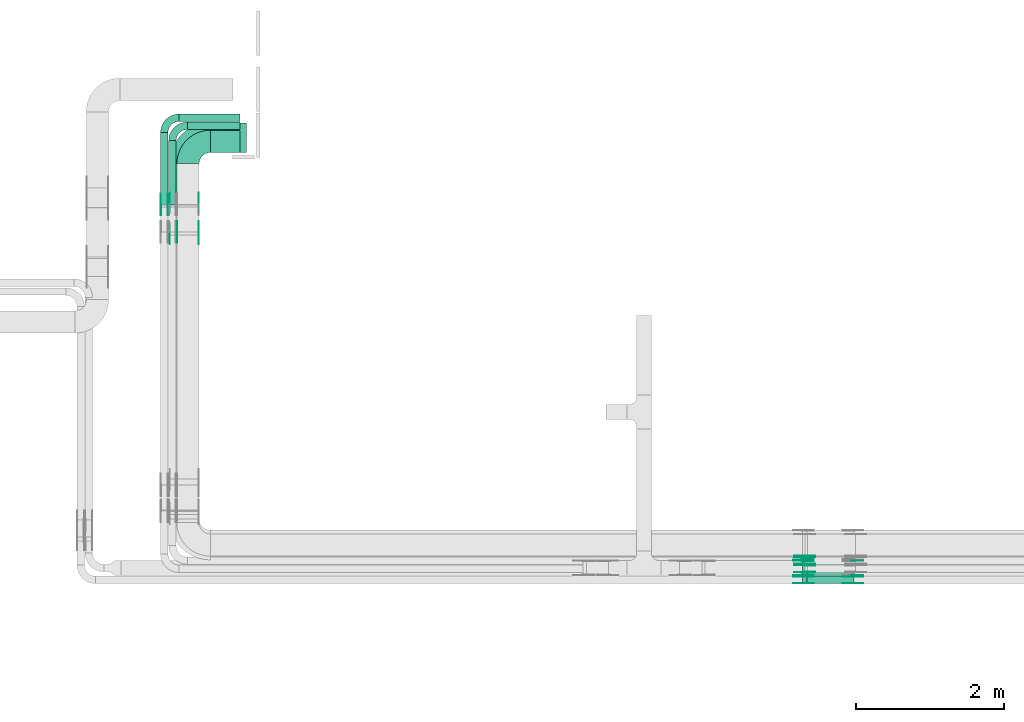
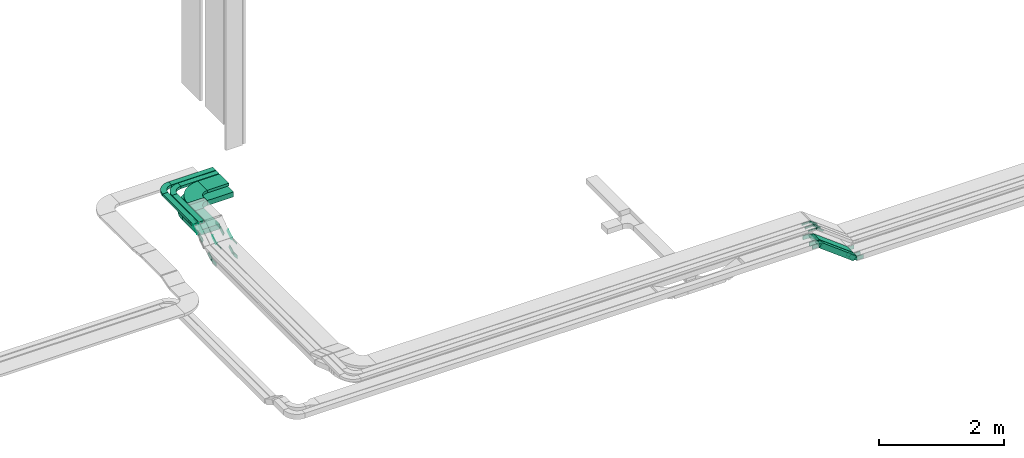
# One storey, part 9 of 28: 46 flow fittings, 9 flow segments.
"""IFC2X3 building model written with IfcOpenShell, lengths in millimetres."""

import ifcopenshell
import ifcopenshell.guid

model = None  # the IFC model being written
_history = None  # IfcOwnerHistory: only IFC2X3 demands one
_inside = {}  # id of a spatial element -> (the spatial element, [elements in it])
_under = {}  # id of a project, library or spatial element -> (it, [spatial elements below it])
_declared = {}  # id of a project -> (the project, [libraries it declares])
_typed = {}  # id of a type object -> (the type object, [elements of that type])
_made_of = {}  # id of a material, layer set ... -> (it, [elements and type objects made of it])


def new_model(schema):
    """Start an empty IFC model of exactly this schema.

    Asked for "IFC4X3", IfcOpenShell would pick the latest addendum, in which some entities
    have other attributes; the version numbers below select the first issue.
    IFC2X3 requires an IfcOwnerHistory on every rooted entity: one is made here for all.
    """
    global model, _history
    if schema == "IFC4X3":
        model = ifcopenshell.file(schema_version=(4, 3, 0, 0))
    else:
        model = ifcopenshell.file(schema=schema)
    _inside.clear()
    _under.clear()
    _declared.clear()
    _typed.clear()
    _made_of.clear()
    _history = None
    if model.schema == "IFC2X3":
        org = make("IfcOrganization", Name="unknown")
        user = make(
            "IfcPersonAndOrganization",
            ThePerson=make("IfcPerson", FamilyName="unknown"),
            TheOrganization=org,
        )
        app = make(
            "IfcApplication",
            ApplicationDeveloper=org,
            Version="unknown",
            ApplicationFullName="unknown",
            ApplicationIdentifier="unknown",
        )
        _history = make(
            "IfcOwnerHistory",
            OwningUser=user,
            OwningApplication=app,
            ChangeAction="ADDED",
            CreationDate=0,
        )
    return model


def make(cls, **values):
    """One entity of the class cls with the attributes given. An attribute that is None is left unset."""
    return model.create_entity(
        cls, **{name: value for name, value in values.items() if value is not None}
    )


def entity(cls, *values):
    """Any entity or typed value of the class cls, its attributes in the order of the schema. None: left unset."""
    e = model.create_entity(cls)
    for i, value in enumerate(values):
        if value is not None:
            e[i] = value
    return e


def rooted(cls, **values):
    """An entity with a GlobalId (a new one), such as an element, a storey or a relation."""
    return make(cls, GlobalId=ifcopenshell.guid.new(), OwnerHistory=_history, **values)


def si_unit(unit_type, name, prefix=None):
    """IfcSIUnit, for example si_unit("LENGTHUNIT", "METRE", prefix="MILLI")."""
    return make("IfcSIUnit", UnitType=unit_type, Prefix=prefix, Name=name)


def converted_unit(unit_type, name, factor, base, dimensions=None, offset=None):
    """IfcConversionBasedUnit, such as the inch: factor (a typed value) times the base unit."""
    return make(
        "IfcConversionBasedUnit"
        if offset is None
        else "IfcConversionBasedUnitWithOffset",
        ConversionOffset=offset,
        Dimensions=None
        if dimensions is None
        else entity("IfcDimensionalExponents", *dimensions),
        UnitType=unit_type,
        Name=name,
        ConversionFactor=make(
            "IfcMeasureWithUnit", ValueComponent=factor, UnitComponent=base
        ),
    )


def derived_unit(unit_type, elements):
    """IfcDerivedUnit: a product of units, each with its exponent."""
    return make(
        "IfcDerivedUnit",
        Elements=[
            make("IfcDerivedUnitElement", Unit=unit, Exponent=power)
            for unit, power in elements
        ],
        UnitType=unit_type,
    )


def assignment(units):
    """IfcUnitAssignment: the units of a project."""
    return None if units is None else make("IfcUnitAssignment", Units=units)


def point(xyz):
    """IfcCartesianPoint."""
    return None if xyz is None else make("IfcCartesianPoint", Coordinates=xyz)


def direction(xyz):
    """IfcDirection."""
    return None if xyz is None else make("IfcDirection", DirectionRatios=xyz)


def frame(location, z_axis=None, x_axis=None):
    """IfcAxis2Placement3D, a coordinate frame: its origin and axes. An axis left out is left unset."""
    return make(
        "IfcAxis2Placement3D",
        Location=point(location),
        Axis=direction(z_axis),
        RefDirection=direction(x_axis),
    )


def frame_2d(location, x_axis=None):
    """IfcAxis2Placement2D, a coordinate frame in the plane: its origin and x axis."""
    return make(
        "IfcAxis2Placement2D", Location=point(location), RefDirection=direction(x_axis)
    )


def origin():
    """The frame at (0, 0, 0) with its axes left unset."""
    return frame((0.0, 0.0, 0.0))


def place(relative_to, where):
    """IfcLocalPlacement: puts the frame where relative to a parent placement (None: the world)."""
    return make(
        "IfcLocalPlacement", PlacementRelTo=relative_to, RelativePlacement=where
    )


def context(
    kind, dimensions, precision=None, world=None, true_north=None, identifier=None
):
    """IfcGeometricRepresentationContext, for example the 3D "Model" context."""
    return make(
        "IfcGeometricRepresentationContext",
        ContextIdentifier=identifier,
        ContextType=kind,
        CoordinateSpaceDimension=dimensions,
        Precision=precision,
        WorldCoordinateSystem=world,
        TrueNorth=true_north,
    )


def subcontext(parent, identifier, kind, view, scale=None):
    """IfcGeometricRepresentationSubContext, for example "Body" below "Model"."""
    return make(
        "IfcGeometricRepresentationSubContext",
        ContextIdentifier=identifier,
        ContextType=kind,
        ParentContext=parent,
        TargetScale=scale,
        TargetView=view,
    )


def project(units=None, contexts=None):
    """IfcProject with its units and contexts."""
    return rooted(
        "IfcProject",
        Name="project",
        RepresentationContexts=contexts,
        UnitsInContext=assignment(units),
    )


def spatial(cls, under=None, at=None, **own):
    """A site, building, storey or space (cls), placed at a placement, below another one or the project."""
    s = rooted(cls, ObjectPlacement=at, **own)
    if under is not None:
        _under.setdefault(under.id(), (under, []))[1].append(s)
    return s


def polyline(points):
    """IfcPolyline through the points."""
    return make("IfcPolyline", Points=[point(p) for p in points])


def circle_curve(where, radius):
    """IfcCircle in the frame where."""
    return make("IfcCircle", Position=where, Radius=radius)


def parameter(value):
    """IfcParameterValue: where a trimmed curve begins or ends, as a parameter of its basis curve."""
    return model.create_entity("IfcParameterValue", value)


def trimmed(basis, trim1, trim2, sense, master):
    """IfcTrimmedCurve: the piece of a basis curve between two trims."""
    return make(
        "IfcTrimmedCurve",
        BasisCurve=basis,
        Trim1=trim1,
        Trim2=trim2,
        SenseAgreement=sense,
        MasterRepresentation=master,
    )


def segment(curve, same_sense, transition):
    """IfcCompositeCurveSegment."""
    return make(
        "IfcCompositeCurveSegment",
        Transition=transition,
        SameSense=same_sense,
        ParentCurve=curve,
    )


def composite_curve(segments, self_intersect=None):
    """IfcCompositeCurve: segments joined end to end."""
    return make("IfcCompositeCurve", Segments=segments, SelfIntersect=self_intersect)


def profile(cls, at=None, kind="AREA", **sizes):
    """A parametric profile (cls). Its sizes go by their IFC names, for example OverallWidth=200.0."""
    return make(cls, ProfileType=kind, Position=at, **sizes)


def rectangle(**sizes):
    """IfcRectangleProfileDef."""
    return profile("IfcRectangleProfileDef", **sizes)


def outline(outer, holes=None, kind="AREA"):
    """IfcArbitraryClosedProfileDef: a profile drawn as a closed curve; with holes, ...WithVoids."""
    if holes is None:
        return make("IfcArbitraryClosedProfileDef", ProfileType=kind, OuterCurve=outer)
    return make(
        "IfcArbitraryProfileDefWithVoids",
        ProfileType=kind,
        OuterCurve=outer,
        InnerCurves=holes,
    )


def extrude(swept, where, along, depth):
    """IfcExtrudedAreaSolid: the profile swept, set in the frame where, extruded along a direction by depth."""
    return make(
        "IfcExtrudedAreaSolid",
        SweptArea=swept,
        Position=where,
        ExtrudedDirection=direction(along),
        Depth=depth,
    )


def shape(context_of_items, identifier, shape_type, items):
    """IfcShapeRepresentation: the items that make up one representation, for example the "Body"."""
    return make(
        "IfcShapeRepresentation",
        ContextOfItems=context_of_items,
        RepresentationIdentifier=identifier,
        RepresentationType=shape_type,
        Items=items,
    )


def source(mapping_origin, context_of_items, identifier, shape_type, items):
    """IfcRepresentationMap: a shape defined once, which mapped items show again and again."""
    return make(
        "IfcRepresentationMap",
        MappingOrigin=mapping_origin,
        MappedRepresentation=shape(context_of_items, identifier, shape_type, items),
    )


def transform(
    local_origin,
    x_axis=None,
    y_axis=None,
    z_axis=None,
    scale=None,
    scale2=None,
    scale3=None,
    uniform=True,
):
    """IfcCartesianTransformationOperator3D, or its non-uniform kind. x_axis, y_axis, z_axis: its Axis1, 2, 3."""
    if uniform:
        return make(
            "IfcCartesianTransformationOperator3D",
            Axis1=direction(x_axis),
            Axis2=direction(y_axis),
            LocalOrigin=point(local_origin),
            Scale=scale,
            Axis3=direction(z_axis),
        )
    return make(
        "IfcCartesianTransformationOperator3DnonUniform",
        Axis1=direction(x_axis),
        Axis2=direction(y_axis),
        LocalOrigin=point(local_origin),
        Scale=scale,
        Axis3=direction(z_axis),
        Scale2=scale2,
        Scale3=scale3,
    )


def mapped(mapping_source, mapping_target):
    """IfcMappedItem: shows the shape of a source again, moved by a transform."""
    return make(
        "IfcMappedItem", MappingSource=mapping_source, MappingTarget=mapping_target
    )


def material(Name=None, Category=None):
    """IfcMaterial."""
    return make("IfcMaterial", Name=Name, Category=Category)


def made_of(thing, what):
    """Note that an element or type object is made of a material, layer set ...; save() writes the relation."""
    if what is not None:
        _made_of.setdefault(what.id(), (what, []))[1].append(thing)
    return thing


def type_object(cls, material=None, **own):
    """A type object (cls), such as IfcWallType, which elements share."""
    return made_of(rooted(cls, **own), material)


def type_shapes(of_type, sources):
    """Give a type object the sources (RepresentationMaps) that its elements show as mapped items."""
    of_type.RepresentationMaps = sources


def element(
    cls,
    number,
    at=None,
    inside=None,
    cuts=None,
    type_object=None,
    material=None,
    context=None,
    identifier="Body",
    shape_type=None,
    held_by="IfcProductDefinitionShape",
    body=None,
    shapes=None,
    **own,
):
    """One element of the class cls, such as IfcWall. Its Tag is "e" and its number.

    at: its placement. inside: the storey or other place that contains it. cuts: it is an
    opening in that element (IfcRelVoidsElement). A single representation is given by context,
    identifier, shape_type and body (its items); several are given by shapes. held_by: the class
    of the entity that holds the representations. save() writes the other relations.
    """
    e = rooted(cls, Tag="e%d" % number, ObjectPlacement=at, **own)
    if body is not None:
        shapes = [shape(context, identifier, shape_type, body)]
    if shapes is not None:
        e.Representation = make(held_by, Representations=shapes)
    if inside is not None:
        _inside.setdefault(inside.id(), (inside, []))[1].append(e)
    if cuts is not None:
        rooted(
            "IfcRelVoidsElement", RelatingBuildingElement=cuts, RelatedOpeningElement=e
        )
    if type_object is not None:
        _typed.setdefault(type_object.id(), (type_object, []))[1].append(e)
    return made_of(e, material)


def aggregate(whole, parts):
    """IfcRelAggregates: a whole, such as a stair, and the parts it consists of."""
    return rooted("IfcRelAggregates", RelatingObject=whole, RelatedObjects=parts)


def save(model, path):
    """Write the relations noted so far, then the file.

    IfcRelAggregates (storeys below a building ...), IfcRelContainedInSpatialStructure (elements
    in a storey), IfcRelDefinesByType, IfcRelAssociatesMaterial and IfcRelDeclares: one each for
    every whole, place, type object, material and project.
    """
    for whole, parts in _under.values():
        aggregate(whole, parts)
    for where, things in _inside.values():
        rooted(
            "IfcRelContainedInSpatialStructure",
            RelatedElements=things,
            RelatingStructure=where,
        )
    for kind, things in _typed.values():
        rooted("IfcRelDefinesByType", RelatedObjects=things, RelatingType=kind)
    for what, things in _made_of.values():
        rooted("IfcRelAssociatesMaterial", RelatedObjects=things, RelatingMaterial=what)
    for by, libraries in _declared.values():
        rooted("IfcRelDeclares", RelatingContext=by, RelatedDefinitions=libraries)
    model.write(path)


model = new_model("IFC2X3")

# Units and contexts
model_context = context("Model", 3, precision=0.01, world=origin(), true_north=direction((6.12303176911189e-17, 1.0)))
body_context = subcontext(model_context, "Body", "Model", "MODEL_VIEW")
ifc_project = project(units=[si_unit("LENGTHUNIT", "METRE", prefix="MILLI"), si_unit("AREAUNIT", "SQUARE_METRE"), si_unit("VOLUMEUNIT", "CUBIC_METRE"), converted_unit("PLANEANGLEUNIT", "DEGREE", entity("IfcRatioMeasure", 0.0174532925199433), si_unit("PLANEANGLEUNIT", "RADIAN"), dimensions=[0, 0, 0, 0, 0, 0, 0]), si_unit("MASSUNIT", "GRAM", prefix="KILO"), derived_unit("MASSDENSITYUNIT", [(si_unit("MASSUNIT", "GRAM", prefix="KILO"), 1), (si_unit("LENGTHUNIT", "METRE"), -3)]), derived_unit("MOMENTOFINERTIAUNIT", [(si_unit("LENGTHUNIT", "METRE"), 4)]), si_unit("TIMEUNIT", "SECOND"), si_unit("FREQUENCYUNIT", "HERTZ"), si_unit("THERMODYNAMICTEMPERATUREUNIT", "DEGREE_CELSIUS"), derived_unit("THERMALTRANSMITTANCEUNIT", [(si_unit("MASSUNIT", "GRAM", prefix="KILO"), 1), (si_unit("THERMODYNAMICTEMPERATUREUNIT", "KELVIN"), -1), (si_unit("TIMEUNIT", "SECOND"), -3)]), derived_unit("VOLUMETRICFLOWRATEUNIT", [(si_unit("LENGTHUNIT", "METRE"), 3), (si_unit("TIMEUNIT", "SECOND"), -1)]), derived_unit("MASSFLOWRATEUNIT", [(si_unit("MASSUNIT", "GRAM", prefix="KILO"), 1), (si_unit("TIMEUNIT", "SECOND"), -1)]), derived_unit("ROTATIONALFREQUENCYUNIT", [(si_unit("TIMEUNIT", "SECOND"), -1)]), si_unit("ELECTRICCURRENTUNIT", "AMPERE"), si_unit("ELECTRICVOLTAGEUNIT", "VOLT"), si_unit("POWERUNIT", "WATT"), si_unit("FORCEUNIT", "NEWTON", prefix="KILO"), si_unit("ILLUMINANCEUNIT", "LUX"), si_unit("LUMINOUSFLUXUNIT", "LUMEN"), si_unit("LUMINOUSINTENSITYUNIT", "CANDELA"), derived_unit("USERDEFINED", [(si_unit("MASSUNIT", "GRAM", prefix="KILO"), -1), (si_unit("LENGTHUNIT", "METRE"), -2), (si_unit("TIMEUNIT", "SECOND"), 3), (si_unit("LUMINOUSFLUXUNIT", "LUMEN"), 1)]), derived_unit("LINEARVELOCITYUNIT", [(si_unit("LENGTHUNIT", "METRE"), 1), (si_unit("TIMEUNIT", "SECOND"), -1)]), si_unit("PRESSUREUNIT", "PASCAL"), derived_unit("USERDEFINED", [(si_unit("LENGTHUNIT", "METRE"), -2), (si_unit("MASSUNIT", "GRAM", prefix="KILO"), 1), (si_unit("TIMEUNIT", "SECOND"), -2)]), derived_unit("LINEARFORCEUNIT", [(si_unit("MASSUNIT", "GRAM", prefix="KILO"), 1), (si_unit("LENGTHUNIT", "METRE"), 1), (si_unit("TIMEUNIT", "SECOND"), -2), (si_unit("LENGTHUNIT", "METRE"), -1)]), derived_unit("PLANARFORCEUNIT", [(si_unit("MASSUNIT", "GRAM", prefix="KILO"), 1), (si_unit("LENGTHUNIT", "METRE"), 1), (si_unit("TIMEUNIT", "SECOND"), -2), (si_unit("LENGTHUNIT", "METRE"), -2)])], contexts=[model_context])

# Site, building, storey
site_placement = place(None, frame((0.0, -0.00077364408347762, 0.0)))
site = spatial("IfcSite", under=ifc_project, at=site_placement, CompositionType="ELEMENT")
building_placement = place(site_placement, origin())
building = spatial("IfcBuilding", under=site, at=building_placement, CompositionType="ELEMENT")
storey_placement = place(building_placement, origin())
storey = spatial("IfcBuildingStorey", under=building, at=storey_placement, CompositionType="ELEMENT", Elevation=0.0)

# Flow segments
cable_carrier_segment_type = type_object("IfcCableCarrierSegmentType", PredefinedType="CABLETRAYSEGMENT")
flow_segment_1_placement = place(storey_placement, frame((23829.8620384306, 8250.00006103528, 2621.54372197819)))
element("IfcFlowSegment", 1, at=flow_segment_1_placement, inside=storey, type_object=cable_carrier_segment_type, context=body_context, shape_type="SweptSolid", body=[
    extrude(rectangle(XDim=100.000000000001, YDim=100.000000000001, at=frame_2d((0.0, -2.1316282072803e-13), x_axis=(0.0, 1.0))), frame((30.0907511576048, 50.0, 516.980780541228), z_axis=(0.79863551004726, 0.0, -0.601815023152092), x_axis=(0.0, 1.0, 0.0)), (0.0, 0.0, 1.0), 792.683776055081),
])
flow_segment_2_placement = place(storey_placement, frame((23829.8620384306, 8360.00006103512, 2621.54372197827)))
element("IfcFlowSegment", 2, at=flow_segment_2_placement, inside=storey, type_object=cable_carrier_segment_type, context=body_context, shape_type="SweptSolid", body=[
    extrude(rectangle(XDim=99.9999999999992, YDim=200.0, at=frame_2d((0.0, 0.0), x_axis=(0.0, 1.0))), frame((30.0907511575918, 100.0, 516.980780541007), z_axis=(0.798635510047449, 0.0, -0.601815023151841), x_axis=(0.0, 1.0, 0.0)), (0.0, 0.0, 1.0), 792.683776055017),
])
flow_segment_3_placement = place(storey_placement, frame((15850.9969238281, 14057.5618465678, 3450.0)))
element("IfcFlowSegment", 3, at=flow_segment_3_placement, inside=storey, type_object=cable_carrier_segment_type, context=body_context, shape_type="SweptSolid", body=[
    extrude(rectangle(XDim=399.000000000009, YDim=300.000000000001, at=frame_2d((0.0, -2.17426077142591e-12), x_axis=(1.0, 0.0))), frame((199.500000000004, 150.0, 0.0)), (0.0, 0.0, 1.0), 49.9999999999989),
])
flow_segment_4_placement = place(storey_placement, frame((15289.9969238281, 13356.5685293336, 3450.0)))
element("IfcFlowSegment", 4, at=flow_segment_4_placement, inside=storey, type_object=cable_carrier_segment_type, context=body_context, shape_type="SweptSolid", body=[
    extrude(rectangle(XDim=859.993317234152, YDim=99.9999999999989, at=frame_2d((1.08002495835535e-12, 1.08357767203415e-12), x_axis=(1.0, 0.0))), frame((50.0, 429.996658617077, 0.0), z_axis=(0.0, 0.0, 1.0), x_axis=(0.0, 1.0, 0.0)), (0.0, 0.0, 1.0), 49.9999999999995),
])
flow_segment_5_placement = place(storey_placement, frame((15540.9969238281, 14367.5618465678, 3450.0)))
element("IfcFlowSegment", 5, at=flow_segment_5_placement, inside=storey, type_object=cable_carrier_segment_type, context=body_context, shape_type="SweptSolid", body=[
    extrude(rectangle(XDim=709.000000000006, YDim=99.9999999999989, at=frame_2d((-1.08002495835535e-12, 0.0), x_axis=(1.0, 0.0))), frame((354.500000000002, 50.0, 0.0)), (0.0, 0.0, 1.0), 49.9999999999995),
])
flow_segment_6_placement = place(storey_placement, frame((15179.9969238281, 13356.5685293336, 3450.0)))
element("IfcFlowSegment", 6, at=flow_segment_6_placement, inside=storey, type_object=cable_carrier_segment_type, context=body_context, shape_type="SweptSolid", body=[
    extrude(rectangle(XDim=969.993317234148, YDim=99.9999999999989, at=frame_2d((1.08002495835535e-12, 1.08357767203415e-12), x_axis=(1.0, 0.0))), frame((50.0, 484.996658617073, 0.0), z_axis=(0.0, 0.0, 1.0), x_axis=(0.0, 1.0, 0.0)), (0.0, 0.0, 1.0), 50.0),
])
flow_segment_7_placement = place(storey_placement, frame((15430.9969238281, 14477.5618465678, 3450.0)))
element("IfcFlowSegment", 7, at=flow_segment_7_placement, inside=storey, type_object=cable_carrier_segment_type, context=body_context, shape_type="SweptSolid", body=[
    extrude(rectangle(XDim=819.000000000007, YDim=99.9999999999989, at=frame_2d((1.08002495835535e-12, 0.0), x_axis=(1.0, 0.0))), frame((409.5, 50.0, 0.0)), (0.0, 0.0, 1.0), 49.9999999999995),
])
flow_segment_8_placement = place(storey_placement, frame((15299.9969238281, 13393.6373317523, 3200.0)))
element("IfcFlowSegment", 8, at=flow_segment_8_placement, inside=storey, type_object=cable_carrier_segment_type, context=body_context, shape_type="SweptSolid", body=[
    extrude(rectangle(XDim=512.924514815445, YDim=400.0, at=frame_2d((-2.1600499167107e-12, 0.0), x_axis=(1.0, 0.0))), frame((200.0, 256.462257407734, 0.0), z_axis=(0.0, 0.0, 1.0), x_axis=(0.0, -1.0, 0.0)), (0.0, 0.0, 1.0), 99.9999999999995),
])
flow_segment_9_placement = place(storey_placement, frame((15850.9969238281, 14057.5618465678, 3200.0)))
element("IfcFlowSegment", 9, at=flow_segment_9_placement, inside=storey, type_object=cable_carrier_segment_type, context=body_context, shape_type="SweptSolid", body=[
    extrude(rectangle(XDim=489.000000000008, YDim=400.0, at=frame_2d((-1.08002495835535e-12, -1.09423581307055e-12), x_axis=(1.0, 0.0))), frame((244.500000000005, 200.0, 0.0)), (0.0, 0.0, 1.0), 100.0),
])

# Flow fittings
ifc_material_1 = material(Name="G")
cable_carrier_fitting_type_1 = type_object("IfcCableCarrierFittingType", PredefinedType="NOTDEFINED", material=ifc_material_1)
shared_shape_1 = source(origin(), body_context, "Body", "SweptSolid", [
    extrude(outline(composite_curve([segment(trimmed(circle_curve(frame_2d((-44.5901162790698, 0.0), x_axis=(1.0, 0.0)), 12.5), [parameter(90.0000000000007)], [parameter(270.0)], True, "PARAMETER"), True, "CONTINUOUS"), segment(polyline([(-44.5901162790697, -12.5), (-33.0901162790698, -12.5)]), True, "CONTINUOUS"), segment(polyline([(-33.0901162790698, -12.5), (-31.2296511627907, -14.5)]), True, "CONTINUOUS"), segment(polyline([(-31.2296511627907, -14.5), (108.90988372093, -14.5)]), True, "CONTINUOUS"), segment(polyline([(108.90988372093, -14.5), (108.90988372093, 14.5)]), True, "CONTINUOUS"), segment(polyline([(108.90988372093, 14.5), (-31.2296511627907, 14.5)]), True, "CONTINUOUS"), segment(polyline([(-31.2296511627907, 14.5), (-33.0901162790698, 12.5)]), True, "CONTINUOUS"), segment(polyline([(-33.0901162790698, 12.5), (-44.5901162790699, 12.5)]), True, "CONTINUOUS")], self_intersect=False)), frame((44.5901162790698, 0.0, 0.0), z_axis=(0.0, 0.0, -1.0), x_axis=(1.0, 0.0, 0.0)), (0.0, 0.0, -1.0), 2.0),
])
type_shapes(cable_carrier_fitting_type_1, [shared_shape_1])
for number, where, z_axis, x_axis in (
    (10, (15184.536923818, 13347.2529131466, 3475.0), (-1.0, 0.0, 0.0), (0.0, 1.0, 0.0)),
    (11, (15404.536923818, 12995.1793167568, 3255.0), (-1.0, 0.0, 0.0), (0.0, -1.0, 0.0)),
    (12, (23870.9969238278, 8624.54006102497, 3375.0), (0.0, -1.0, 0.0), (-1.0, 0.0, 0.0)),
    (13, (23870.996923828, 8514.54006102488, 3375.0), (0.0, -1.0, 0.0), (-1.0, 0.0, 0.0)),
    (14, (23870.996923828, 8404.540061025, 3375.0), (0.0, -1.0, 0.0), (-1.0, 0.0, 0.0)),
):
    element("IfcFlowFitting", number, at=place(storey_placement, frame(where, z_axis=z_axis, x_axis=x_axis)), inside=storey, type_object=cable_carrier_fitting_type_1, material=ifc_material_1, context=body_context, shape_type="MappedRepresentation", body=[
        mapped(shared_shape_1, transform((0.0, 0.0, 0.0), scale=1.0)),
    ])
cable_carrier_fitting_type_2 = type_object("IfcCableCarrierFittingType", PredefinedType="NOTDEFINED", material=ifc_material_1)
shared_shape_2 = source(origin(), body_context, "Body", "SweptSolid", [
    extrude(outline(composite_curve([segment(trimmed(circle_curve(frame_2d((-44.5901162790697, 0.0), x_axis=(1.0, 0.0)), 12.5), [parameter(90.0000000000007)], [parameter(270.0)], True, "PARAMETER"), True, "CONTINUOUS"), segment(polyline([(-44.5901162790697, -12.5), (-33.0901162790697, -12.5)]), True, "CONTINUOUS"), segment(polyline([(-33.0901162790697, -12.5), (-31.2296511627907, -14.5)]), True, "CONTINUOUS"), segment(polyline([(-31.2296511627907, -14.5), (108.90988372093, -14.5)]), True, "CONTINUOUS"), segment(polyline([(108.90988372093, -14.5), (108.90988372093, 14.5)]), True, "CONTINUOUS"), segment(polyline([(108.90988372093, 14.5), (-31.2296511627907, 14.5)]), True, "CONTINUOUS"), segment(polyline([(-31.2296511627907, 14.5), (-33.0901162790698, 12.5)]), True, "CONTINUOUS"), segment(polyline([(-33.0901162790698, 12.5), (-44.5901162790699, 12.5)]), True, "CONTINUOUS")], self_intersect=False)), frame((44.5901162790697, 0.0, 0.0)), (0.0, 0.0, 1.0), 2.0),
])
type_shapes(cable_carrier_fitting_type_2, [shared_shape_2])
for number, where, z_axis, x_axis in (
    (15, (15275.4569238383, 13347.2529131466, 3475.0), (1.0, 0.0, 0.0), (0.0, 1.0, 0.0)),
    (16, (15695.4569238383, 12995.1793167568, 3255.0), (1.0, 0.0, 0.0), (0.0, -1.0, 0.0)),
    (17, (23870.996923828, 8605.4600610452, 3375.0), (0.0, 1.0, 0.0), (-1.0, 0.0, 0.0)),
    (18, (23870.996923828, 8495.46006104532, 3375.0), (0.0, 1.0, 0.0), (-1.0, 0.0, 0.0)),
):
    element("IfcFlowFitting", number, at=place(storey_placement, frame(where, z_axis=z_axis, x_axis=x_axis)), inside=storey, type_object=cable_carrier_fitting_type_2, material=ifc_material_1, context=body_context, shape_type="MappedRepresentation", body=[
        mapped(shared_shape_2, transform((0.0, 0.0, 0.0), scale=1.0)),
    ])
cable_carrier_fitting_type_3 = type_object("IfcCableCarrierFittingType", PredefinedType="NOTDEFINED", material=ifc_material_1)
shared_shape_3 = source(origin(), body_context, "Body", "SweptSolid", [
    extrude(outline(composite_curve([segment(trimmed(circle_curve(frame_2d((-44.5901162790698, 0.0), x_axis=(1.0, 0.0)), 12.5), [parameter(90.0000000000007)], [parameter(270.0)], True, "PARAMETER"), True, "CONTINUOUS"), segment(polyline([(-44.5901162790697, -12.5), (-33.0901162790698, -12.5)]), True, "CONTINUOUS"), segment(polyline([(-33.0901162790698, -12.5), (-31.2296511627907, -14.5)]), True, "CONTINUOUS"), segment(polyline([(-31.2296511627907, -14.5), (108.90988372093, -14.5)]), True, "CONTINUOUS"), segment(polyline([(108.90988372093, -14.5), (108.90988372093, 14.5)]), True, "CONTINUOUS"), segment(polyline([(108.90988372093, 14.5), (-31.2296511627907, 14.5)]), True, "CONTINUOUS"), segment(polyline([(-31.2296511627907, 14.5), (-33.0901162790698, 12.5)]), True, "CONTINUOUS"), segment(polyline([(-33.0901162790698, 12.5), (-44.5901162790699, 12.5)]), True, "CONTINUOUS")], self_intersect=False)), frame((44.5901162790698, 0.0, 0.0), z_axis=(0.0, 0.0, -1.0), x_axis=(1.0, 0.0, 0.0)), (0.0, 0.0, -1.0), 2.0),
])
type_shapes(cable_carrier_fitting_type_3, [shared_shape_3])
for number, where, z_axis, x_axis in (
    (19, (15273.4569238383, 13347.2529131466, 3475.0), (1.0, 0.0, 0.0), (0.0, -0.848048096156981, -0.529919264232316)),
    (20, (15693.4569238383, 12995.1793167568, 3255.0), (1.0, 0.0, 0.0), (0.0, 0.848048096156905, 0.529919264232438)),
    (21, (23870.9969238279, 8603.4600610452, 3375.0), (0.0, 1.0, 0.0), (0.798635510047374, 0.0, -0.601815023151941)),
    (22, (23870.996923828, 8493.46006104532, 3375.0), (0.0, 1.0, 0.0), (0.798635510047285, 0.0, -0.601815023152059)),
):
    element("IfcFlowFitting", number, at=place(storey_placement, frame(where, z_axis=z_axis, x_axis=x_axis)), inside=storey, type_object=cable_carrier_fitting_type_3, material=ifc_material_1, context=body_context, shape_type="MappedRepresentation", body=[
        mapped(shared_shape_3, transform((0.0, 0.0, 0.0), scale=1.0)),
    ])
cable_carrier_fitting_type_4 = type_object("IfcCableCarrierFittingType", PredefinedType="NOTDEFINED", material=ifc_material_1)
shared_shape_4 = source(origin(), body_context, "Body", "SweptSolid", [
    extrude(outline(composite_curve([segment(trimmed(circle_curve(frame_2d((-44.5901162790697, 0.0), x_axis=(1.0, 0.0)), 12.5), [parameter(90.0000000000007)], [parameter(270.0)], True, "PARAMETER"), True, "CONTINUOUS"), segment(polyline([(-44.5901162790697, -12.5), (-33.0901162790697, -12.5)]), True, "CONTINUOUS"), segment(polyline([(-33.0901162790697, -12.5), (-31.2296511627907, -14.5)]), True, "CONTINUOUS"), segment(polyline([(-31.2296511627907, -14.5), (108.90988372093, -14.5)]), True, "CONTINUOUS"), segment(polyline([(108.90988372093, -14.5), (108.90988372093, 14.5)]), True, "CONTINUOUS"), segment(polyline([(108.90988372093, 14.5), (-31.2296511627907, 14.5)]), True, "CONTINUOUS"), segment(polyline([(-31.2296511627907, 14.5), (-33.0901162790698, 12.5)]), True, "CONTINUOUS"), segment(polyline([(-33.0901162790698, 12.5), (-44.5901162790699, 12.5)]), True, "CONTINUOUS")], self_intersect=False)), frame((44.5901162790697, 0.0, 0.0)), (0.0, 0.0, 1.0), 2.0),
])
type_shapes(cable_carrier_fitting_type_4, [shared_shape_4])
for number, where, z_axis, x_axis in (
    (23, (15186.536923818, 13347.2529131466, 3475.0), (-1.0, 0.0, 0.0), (0.0, -0.848048096156981, -0.529919264232316)),
    (24, (15406.536923818, 12995.1793167568, 3255.0), (-1.0, 0.0, 0.0), (0.0, 0.848048096156905, 0.529919264232438)),
    (25, (23870.9969238278, 8626.54006102497, 3375.0), (0.0, -1.0, 0.0), (0.798635510047512, 0.0, -0.601815023151758)),
    (26, (23870.9969238279, 8516.54006102489, 3375.0), (0.0, -1.0, 0.0), (0.798635510047374, 0.0, -0.601815023151941)),
    (27, (23870.996923828, 8406.540061025, 3375.0), (0.0, -1.0, 0.0), (0.798635510047285, 0.0, -0.601815023152059)),
):
    element("IfcFlowFitting", number, at=place(storey_placement, frame(where, z_axis=z_axis, x_axis=x_axis)), inside=storey, type_object=cable_carrier_fitting_type_4, material=ifc_material_1, context=body_context, shape_type="MappedRepresentation", body=[
        mapped(shared_shape_4, transform((0.0, 0.0, 0.0), scale=1.0)),
    ])
cable_carrier_fitting_type_5 = type_object("IfcCableCarrierFittingType", PredefinedType="NOTDEFINED", material=ifc_material_1)
shared_shape_5 = source(origin(), body_context, "Body", "SweptSolid", [
    extrude(outline(composite_curve([segment(trimmed(circle_curve(frame_2d((-41.4651162790697, 0.0), x_axis=(1.0, 0.0)), 25.0), [parameter(90.0000000000007)], [parameter(270.0)], True, "PARAMETER"), True, "CONTINUOUS"), segment(polyline([(-41.4651162790697, -25.0), (-29.9651162790697, -25.0)]), True, "CONTINUOUS"), segment(polyline([(-29.9651162790697, -25.0), (-28.1046511627907, -38.5)]), True, "CONTINUOUS"), segment(polyline([(-28.1046511627907, -38.5), (99.5348837209303, -38.5)]), True, "CONTINUOUS"), segment(polyline([(99.5348837209303, -38.5), (99.5348837209303, 38.5)]), True, "CONTINUOUS"), segment(polyline([(99.5348837209303, 38.5), (-28.1046511627907, 38.5)]), True, "CONTINUOUS"), segment(polyline([(-28.1046511627907, 38.5), (-29.9651162790697, 25.0)]), True, "CONTINUOUS"), segment(polyline([(-29.9651162790697, 25.0), (-41.46511627907, 25.0)]), True, "CONTINUOUS")], self_intersect=False)), frame((41.4651162790697, 0.0, 0.0), z_axis=(0.0, 0.0, -1.0), x_axis=(1.0, 0.0, 0.0)), (0.0, 0.0, -1.0), 2.0),
])
type_shapes(cable_carrier_fitting_type_5, [shared_shape_5])
for number, where, z_axis, x_axis in (
    (28, (23844.724290081, 8345.46006104545, 3150.0), (0.0, 1.0, 0.0), (0.798635510047293, 0.0, -0.601815023152048)),
    (29, (24508.2467008912, 8254.54006102513, 2650.0), (0.0, -1.0, 0.0), (1.0, 0.0, 0.0)),
    (30, (24508.2467008914, 8364.54006102496, 2650.0), (0.0, -1.0, 0.0), (1.0, 0.0, 0.0)),
    (31, (23844.7242900809, 8574.54006102507, 3150.0), (0.0, -1.0, 0.0), (-1.0, 0.0, 0.0)),
    (32, (23844.7242900811, 8364.54006102496, 3150.0), (0.0, -1.0, 0.0), (-1.0, 0.0, 0.0)),
    (33, (15304.536923818, 13377.1530809214, 3250.0), (-1.0, 0.0, 0.0), (0.0, 1.0, 0.0)),
    (34, (15304.536923818, 12961.0661033707, 2990.0), (-1.0, 0.0, 0.0), (0.0, -1.0, 0.0)),
):
    element("IfcFlowFitting", number, at=place(storey_placement, frame(where, z_axis=z_axis, x_axis=x_axis)), inside=storey, type_object=cable_carrier_fitting_type_5, material=ifc_material_1, context=body_context, shape_type="MappedRepresentation", body=[
        mapped(shared_shape_5, transform((0.0, 0.0, 0.0), scale=1.0)),
    ])
cable_carrier_fitting_type_6 = type_object("IfcCableCarrierFittingType", PredefinedType="NOTDEFINED", material=ifc_material_1)
shared_shape_6 = source(origin(), body_context, "Body", "SweptSolid", [
    extrude(outline(composite_curve([segment(trimmed(circle_curve(frame_2d((-41.4651162790697, 0.0), x_axis=(1.0, 0.0)), 25.0), [parameter(90.0000000000007)], [parameter(270.0)], True, "PARAMETER"), True, "CONTINUOUS"), segment(polyline([(-41.4651162790697, -25.0), (-29.9651162790697, -25.0)]), True, "CONTINUOUS"), segment(polyline([(-29.9651162790697, -25.0), (-28.1046511627907, -38.5)]), True, "CONTINUOUS"), segment(polyline([(-28.1046511627907, -38.5), (99.5348837209303, -38.5)]), True, "CONTINUOUS"), segment(polyline([(99.5348837209303, -38.5), (99.5348837209303, 38.5)]), True, "CONTINUOUS"), segment(polyline([(99.5348837209303, 38.5), (-28.1046511627907, 38.5)]), True, "CONTINUOUS"), segment(polyline([(-28.1046511627907, 38.5), (-29.9651162790697, 25.0)]), True, "CONTINUOUS"), segment(polyline([(-29.9651162790697, 25.0), (-41.46511627907, 25.0)]), True, "CONTINUOUS")], self_intersect=False)), frame((41.4651162790697, 0.0, 0.0)), (0.0, 0.0, 1.0), 2.0),
])
type_shapes(cable_carrier_fitting_type_6, [shared_shape_6])
for number, where, z_axis, x_axis in (
    (35, (23844.724290081, 8254.54006102513, 3150.0), (0.0, -1.0, 0.0), (0.798635510047293, 0.0, -0.601815023152048)),
    (36, (24508.2467008912, 8345.46006104544, 2650.0), (0.0, 1.0, 0.0), (1.0, 0.0, 0.0)),
    (37, (24508.2467008914, 8555.46006104528, 2650.0), (0.0, 1.0, 0.0), (1.0, 0.0, 0.0)),
    (38, (23844.7242900811, 8555.46006104528, 3150.0), (0.0, 1.0, 0.0), (-1.0, 0.0, 0.0)),
    (39, (15695.4569238383, 13377.1530809214, 3250.0), (1.0, 0.0, 0.0), (0.0, 1.0, 0.0)),
    (40, (15695.4569238383, 12961.0661033707, 2990.0), (1.0, 0.0, 0.0), (0.0, -1.0, 0.0)),
):
    element("IfcFlowFitting", number, at=place(storey_placement, frame(where, z_axis=z_axis, x_axis=x_axis)), inside=storey, type_object=cable_carrier_fitting_type_6, material=ifc_material_1, context=body_context, shape_type="MappedRepresentation", body=[
        mapped(shared_shape_6, transform((0.0, 0.0, 0.0), scale=1.0)),
    ])
cable_carrier_fitting_type_7 = type_object("IfcCableCarrierFittingType", PredefinedType="NOTDEFINED", material=ifc_material_1)
shared_shape_7 = source(origin(), body_context, "Body", "SweptSolid", [
    extrude(outline(composite_curve([segment(trimmed(circle_curve(frame_2d((-41.4651162790697, 0.0), x_axis=(1.0, 0.0)), 25.0), [parameter(90.0000000000007)], [parameter(270.0)], True, "PARAMETER"), True, "CONTINUOUS"), segment(polyline([(-41.4651162790697, -25.0), (-29.9651162790697, -25.0)]), True, "CONTINUOUS"), segment(polyline([(-29.9651162790697, -25.0), (-28.1046511627907, -38.5)]), True, "CONTINUOUS"), segment(polyline([(-28.1046511627907, -38.5), (99.5348837209303, -38.5)]), True, "CONTINUOUS"), segment(polyline([(99.5348837209303, -38.5), (99.5348837209303, 38.5)]), True, "CONTINUOUS"), segment(polyline([(99.5348837209303, 38.5), (-28.1046511627907, 38.5)]), True, "CONTINUOUS"), segment(polyline([(-28.1046511627907, 38.5), (-29.9651162790697, 25.0)]), True, "CONTINUOUS"), segment(polyline([(-29.9651162790697, 25.0), (-41.46511627907, 25.0)]), True, "CONTINUOUS")], self_intersect=False)), frame((41.4651162790697, 0.0, 0.0), z_axis=(0.0, 0.0, -1.0), x_axis=(1.0, 0.0, 0.0)), (0.0, 0.0, -1.0), 2.0),
])
type_shapes(cable_carrier_fitting_type_7, [shared_shape_7])
for number, where, z_axis, x_axis in (
    (41, (23844.724290081, 8256.54006102513, 3150.0), (0.0, -1.0, 0.0), (-1.0, 0.0, 0.0)),
    (42, (24508.2467008913, 8343.46006104544, 2650.0), (0.0, 1.0, 0.0), (-0.79863551004728, 0.0, 0.601815023152065)),
    (43, (23844.7242900811, 8553.46006104528, 3150.0), (0.0, 1.0, 0.0), (0.798635510047463, 0.0, -0.601815023151822)),
    (44, (15693.4569238383, 13377.1530809214, 3250.0), (1.0, 0.0, 0.0), (0.0, -0.848048096156376, -0.529919264233284)),
    (45, (15693.4569238383, 12961.0661033707, 2990.0), (1.0, 0.0, 0.0), (0.0, 0.848048096156366, 0.529919264233302)),
):
    element("IfcFlowFitting", number, at=place(storey_placement, frame(where, z_axis=z_axis, x_axis=x_axis)), inside=storey, type_object=cable_carrier_fitting_type_7, material=ifc_material_1, context=body_context, shape_type="MappedRepresentation", body=[
        mapped(shared_shape_7, transform((0.0, 0.0, 0.0), scale=1.0)),
    ])
cable_carrier_fitting_type_8 = type_object("IfcCableCarrierFittingType", PredefinedType="NOTDEFINED", material=ifc_material_1)
shared_shape_8 = source(origin(), body_context, "Body", "SweptSolid", [
    extrude(outline(composite_curve([segment(trimmed(circle_curve(frame_2d((-41.4651162790697, 0.0), x_axis=(1.0, 0.0)), 25.0), [parameter(90.0000000000007)], [parameter(270.0)], True, "PARAMETER"), True, "CONTINUOUS"), segment(polyline([(-41.4651162790697, -25.0), (-29.9651162790697, -25.0)]), True, "CONTINUOUS"), segment(polyline([(-29.9651162790697, -25.0), (-28.1046511627907, -38.5)]), True, "CONTINUOUS"), segment(polyline([(-28.1046511627907, -38.5), (99.5348837209303, -38.5)]), True, "CONTINUOUS"), segment(polyline([(99.5348837209303, -38.5), (99.5348837209303, 38.5)]), True, "CONTINUOUS"), segment(polyline([(99.5348837209303, 38.5), (-28.1046511627907, 38.5)]), True, "CONTINUOUS"), segment(polyline([(-28.1046511627907, 38.5), (-29.9651162790697, 25.0)]), True, "CONTINUOUS"), segment(polyline([(-29.9651162790697, 25.0), (-41.46511627907, 25.0)]), True, "CONTINUOUS")], self_intersect=False)), frame((41.4651162790697, 0.0, 0.0)), (0.0, 0.0, 1.0), 2.0),
])
type_shapes(cable_carrier_fitting_type_8, [shared_shape_8])
for number, where, z_axis, x_axis in (
    (46, (23844.724290081, 8343.46006104544, 3150.0), (0.0, 1.0, 0.0), (-1.0, 0.0, 0.0)),
    (47, (24508.2467008913, 8256.54006102513, 2650.0), (0.0, -1.0, 0.0), (-0.79863551004728, 0.0, 0.601815023152065)),
    (48, (23844.7242900809, 8576.54006102507, 3150.0), (0.0, -1.0, 0.0), (0.798635510047464, 0.0, -0.601815023151821)),
    (49, (23844.7242900811, 8366.54006102497, 3150.0), (0.0, -1.0, 0.0), (0.798635510047463, 0.0, -0.601815023151822)),
    (50, (15306.536923818, 13377.1530809214, 3250.0), (-1.0, 0.0, 0.0), (0.0, -0.848048096156376, -0.529919264233284)),
    (51, (15306.536923818, 12961.0661033707, 2990.0), (-1.0, 0.0, 0.0), (0.0, 0.848048096156366, 0.529919264233302)),
):
    element("IfcFlowFitting", number, at=place(storey_placement, frame(where, z_axis=z_axis, x_axis=x_axis)), inside=storey, type_object=cable_carrier_fitting_type_8, material=ifc_material_1, context=body_context, shape_type="MappedRepresentation", body=[
        mapped(shared_shape_8, transform((0.0, 0.0, 0.0), scale=1.0)),
    ])
ifc_material_2 = material()
cable_carrier_fitting_type_9 = type_object("IfcCableCarrierFittingType", Name="470_DKC_S5_Variable Angle Elbow 0-45:-", PredefinedType="NOTDEFINED", material=ifc_material_2)
shared_shape_9 = source(origin(), body_context, "Body", "SweptSolid", [
    extrude(outline(composite_curve([segment(polyline([(-100.750000000001, -150.25), (-99.7499999999994, -150.25)]), True, "CONTINUOUS"), segment(trimmed(circle_curve(frame_2d((-99.7499999999997, 99.7499999999995), x_axis=(0.0, -1.0)), 250.0), [parameter(0.0)], [parameter(90.0000000000001)], True, "PARAMETER"), True, "CONTINUOUS"), segment(polyline([(150.25, 99.75), (150.25, 100.749999999999)]), True, "CONTINUOUS"), segment(polyline([(150.25, 100.749999999999), (50.25, 100.75)]), True, "CONTINUOUS"), segment(polyline([(50.25, 100.75), (50.25, 99.7499999999998)]), True, "CONTINUOUS"), segment(trimmed(circle_curve(frame_2d((-99.7499999999997, 99.7499999999995), x_axis=(0.0, -1.0)), 150.0), [parameter(0.0)], [parameter(90.0000000000001)], True, "PARAMETER"), False, "CONTINUOUS"), segment(polyline([(-99.7499999999994, -50.2500000000003), (-100.750000000001, -50.2500000000003)]), True, "CONTINUOUS"), segment(polyline([(-100.750000000001, -50.2500000000003), (-100.750000000001, -150.25)]), True, "CONTINUOUS")], self_intersect=False)), frame((-100.249999999991, 100.249999999992, -25.0)), (0.0, 0.0, 1.0), 49.9999999999997),
])
type_shapes(cable_carrier_fitting_type_9, [shared_shape_9])
for number, where, z_axis, x_axis, name in (
    (52, (15339.9969238281, 14417.5618465678, 3475.0), (0.0, 0.0, 1.0), (-1.0, 0.0, 0.0), "470_DKC_S5_Variable Angle Elbow 0-45:-"),
    (53, (15229.9969238281, 14527.5618465678, 3475.0), (0.0, 0.0, 1.0), (-1.0, 0.0, 0.0), "470_DKC_S5_Variable Angle Elbow 0-45:-"),
):
    element("IfcFlowFitting", number, at=place(storey_placement, frame(where, z_axis=z_axis, x_axis=x_axis)), inside=storey, type_object=cable_carrier_fitting_type_9, material=ifc_material_2, Name=name, ObjectType="470_DKC_S5_Variable Angle Elbow 0-45:-", context=body_context, shape_type="MappedRepresentation", body=[
        mapped(shared_shape_9, transform((0.0, 0.0, 0.0), scale=1.0)),
    ])
cable_carrier_fitting_type_10 = type_object("IfcCableCarrierFittingType", Name="470_DKC_S5_Variable Angle Elbow 0-45:-", PredefinedType="NOTDEFINED", material=ifc_material_2)
shared_shape_10 = source(origin(), body_context, "Body", "SweptSolid", [
    extrude(outline(composite_curve([segment(polyline([(-150.749999999996, -300.250000000003), (-149.749999999994, -300.250000000003)]), True, "CONTINUOUS"), segment(trimmed(circle_curve(frame_2d((-149.750000000002, 149.749999999997), x_axis=(0.0, -1.0)), 450.0), [parameter(0.0)], [parameter(90.0000000000001)], True, "PARAMETER"), True, "CONTINUOUS"), segment(polyline([(300.249999999997, 149.750000000005), (300.249999999997, 150.750000000004)]), True, "CONTINUOUS"), segment(polyline([(300.249999999997, 150.750000000003), (0.249999999997449, 150.750000000002)]), True, "CONTINUOUS"), segment(polyline([(0.249999999997449, 150.750000000002), (0.249999999997438, 149.75)]), True, "CONTINUOUS"), segment(trimmed(circle_curve(frame_2d((-149.750000000002, 149.749999999997), x_axis=(0.0, -1.0)), 150.0), [parameter(0.0)], [parameter(90.0000000000001)], True, "PARAMETER"), False, "CONTINUOUS"), segment(polyline([(-149.749999999999, -0.250000000002818), (-150.750000000001, -0.250000000002835)]), True, "CONTINUOUS"), segment(polyline([(-150.750000000001, -0.250000000002835), (-150.749999999996, -300.250000000003)]), True, "CONTINUOUS")], self_intersect=False)), frame((-150.249999999991, 150.249999999992, -25.0)), (0.0, 0.0, 1.0), 49.9999999999974),
])
type_shapes(cable_carrier_fitting_type_10, [shared_shape_10])
flow_fitting_1_placement = place(storey_placement, frame((15549.9969238281, 14207.5618465678, 3475.0), z_axis=(0.0, 0.0, 1.0), x_axis=(-1.0, 0.0, 0.0)))
element("IfcFlowFitting", 54, at=flow_fitting_1_placement, inside=storey, type_object=cable_carrier_fitting_type_10, material=ifc_material_2, Name="470_DKC_S5_Variable Angle Elbow 0-45:-", ObjectType="470_DKC_S5_Variable Angle Elbow 0-45:-", context=body_context, shape_type="MappedRepresentation", body=[
    mapped(shared_shape_10, transform((0.0, 0.0, 0.0), scale=1.0)),
])
cable_carrier_fitting_type_11 = type_object("IfcCableCarrierFittingType", Name="470_DKC_S5_Variable Angle Elbow 0-45:-", PredefinedType="NOTDEFINED", material=ifc_material_2)
shared_shape_11 = source(origin(), body_context, "Body", "SweptSolid", [
    extrude(outline(composite_curve([segment(polyline([(-175.750000000001, -375.25), (-174.749999999999, -375.25)]), True, "CONTINUOUS"), segment(trimmed(circle_curve(frame_2d((-174.75, 174.75), x_axis=(0.0, -1.0)), 550.0), [parameter(0.0)], [parameter(90.0)], True, "PARAMETER"), True, "CONTINUOUS"), segment(polyline([(375.25, 174.75), (375.25, 175.749999999997)]), True, "CONTINUOUS"), segment(polyline([(375.25, 175.749999999997), (-24.7500000000001, 175.750000000002)]), True, "CONTINUOUS"), segment(polyline([(-24.7500000000001, 175.750000000002), (-24.75, 174.75)]), True, "CONTINUOUS"), segment(trimmed(circle_curve(frame_2d((-174.75, 174.75), x_axis=(0.0, -1.0)), 150.0), [parameter(0.0)], [parameter(90.0)], True, "PARAMETER"), False, "CONTINUOUS"), segment(polyline([(-174.749999999999, 24.7499999999999), (-175.750000000001, 24.7499999999999)]), True, "CONTINUOUS"), segment(polyline([(-175.750000000001, 24.7499999999999), (-175.750000000001, -375.25)]), True, "CONTINUOUS")], self_intersect=False)), frame((-175.24999999999, 175.249999999992, -50.0)), (0.0, 0.0, 1.0), 99.9999999999956),
])
type_shapes(cable_carrier_fitting_type_11, [shared_shape_11])
flow_fitting_2_placement = place(storey_placement, frame((15499.9969238281, 14257.5618465678, 3250.0), z_axis=(0.0, 0.0, 1.0), x_axis=(-1.0, 0.0, 0.0)))
element("IfcFlowFitting", 55, at=flow_fitting_2_placement, inside=storey, type_object=cable_carrier_fitting_type_11, material=ifc_material_2, Name="470_DKC_S5_Variable Angle Elbow 0-45:-", ObjectType="470_DKC_S5_Variable Angle Elbow 0-45:-", context=body_context, shape_type="MappedRepresentation", body=[
    mapped(shared_shape_11, transform((0.0, 0.0, 0.0), scale=1.0)),
])

save(model, "model.ifc")
